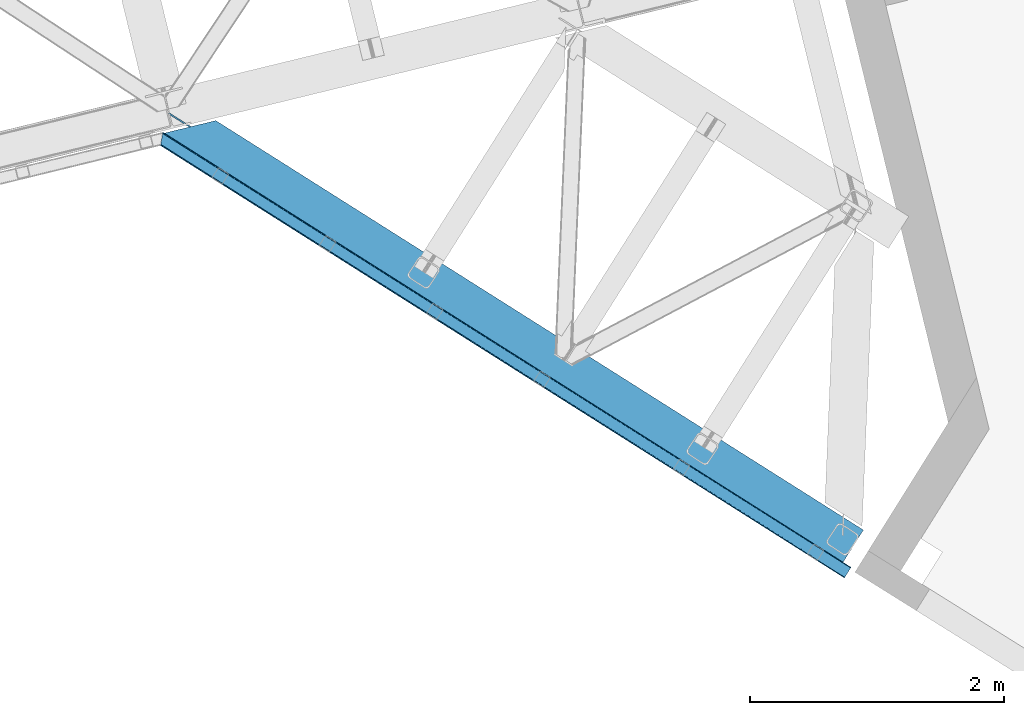
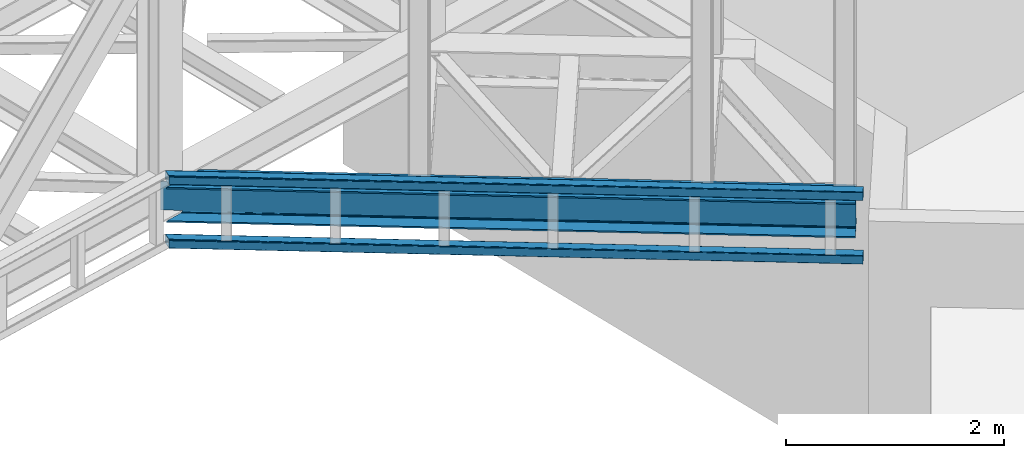
# One storey, part 71 of 93: 3 beams.
"""IFC4 building model written with IfcOpenShell, lengths in millimetres."""

from ifc_helpers import new_model, entity, si_unit, converted_unit, derived_unit, direction, frame, origin, place, context, subcontext, project, spatial, triangles, polygons, material, type_object, element, save


model = new_model("IFC4")

# Units and contexts
model_context = context("Model", 3, precision=0.01, world=origin(), true_north=direction((6.12303176911189e-17, 1.0)))
plan_context = context("Plan", 3, precision=0.01, world=origin(), true_north=direction((6.12303176911189e-17, 1.0)))
body_context = subcontext(model_context, "Body", "Model", "MODEL_VIEW")
ifc_project = project(units=[si_unit("LENGTHUNIT", "METRE", prefix="MILLI"), si_unit("AREAUNIT", "SQUARE_METRE"), si_unit("VOLUMEUNIT", "CUBIC_METRE"), converted_unit("PLANEANGLEUNIT", "DEGREE", entity("IfcRatioMeasure", 0.0174532925199433), si_unit("PLANEANGLEUNIT", "RADIAN"), dimensions=[0, 0, 0, 0, 0, 0, 0]), si_unit("MASSUNIT", "GRAM", prefix="KILO"), derived_unit("MASSDENSITYUNIT", [(si_unit("MASSUNIT", "GRAM", prefix="KILO"), 1), (si_unit("LENGTHUNIT", "METRE"), -3)]), derived_unit("MOMENTOFINERTIAUNIT", [(si_unit("LENGTHUNIT", "METRE"), 4)]), si_unit("TIMEUNIT", "SECOND"), si_unit("FREQUENCYUNIT", "HERTZ"), si_unit("THERMODYNAMICTEMPERATUREUNIT", "DEGREE_CELSIUS"), derived_unit("THERMALTRANSMITTANCEUNIT", [(si_unit("MASSUNIT", "GRAM", prefix="KILO"), 1), (si_unit("THERMODYNAMICTEMPERATUREUNIT", "KELVIN"), -1), (si_unit("TIMEUNIT", "SECOND"), -3)]), derived_unit("VOLUMETRICFLOWRATEUNIT", [(si_unit("LENGTHUNIT", "METRE"), 3), (si_unit("TIMEUNIT", "SECOND"), -1)]), derived_unit("MASSFLOWRATEUNIT", [(si_unit("MASSUNIT", "GRAM", prefix="KILO"), 1), (si_unit("TIMEUNIT", "SECOND"), -1)]), derived_unit("ROTATIONALFREQUENCYUNIT", [(si_unit("TIMEUNIT", "SECOND"), -1)]), si_unit("ELECTRICCURRENTUNIT", "AMPERE"), si_unit("ELECTRICVOLTAGEUNIT", "VOLT"), si_unit("POWERUNIT", "WATT"), si_unit("FORCEUNIT", "NEWTON", prefix="KILO"), si_unit("ILLUMINANCEUNIT", "LUX"), si_unit("LUMINOUSFLUXUNIT", "LUMEN"), si_unit("LUMINOUSINTENSITYUNIT", "CANDELA"), derived_unit("USERDEFINED", [(si_unit("MASSUNIT", "GRAM", prefix="KILO"), -1), (si_unit("LENGTHUNIT", "METRE"), -2), (si_unit("TIMEUNIT", "SECOND"), 3), (si_unit("LUMINOUSFLUXUNIT", "LUMEN"), 1)]), derived_unit("LINEARVELOCITYUNIT", [(si_unit("LENGTHUNIT", "METRE"), 1), (si_unit("TIMEUNIT", "SECOND"), -1)]), si_unit("PRESSUREUNIT", "PASCAL"), derived_unit("USERDEFINED", [(si_unit("LENGTHUNIT", "METRE"), -2), (si_unit("MASSUNIT", "GRAM", prefix="KILO"), 1), (si_unit("TIMEUNIT", "SECOND"), -2)]), derived_unit("LINEARFORCEUNIT", [(si_unit("MASSUNIT", "GRAM", prefix="KILO"), 1), (si_unit("LENGTHUNIT", "METRE"), 1), (si_unit("TIMEUNIT", "SECOND"), -2), (si_unit("LENGTHUNIT", "METRE"), -1)]), derived_unit("PLANARFORCEUNIT", [(si_unit("MASSUNIT", "GRAM", prefix="KILO"), 1), (si_unit("LENGTHUNIT", "METRE"), 1), (si_unit("TIMEUNIT", "SECOND"), -2), (si_unit("LENGTHUNIT", "METRE"), -2)])], contexts=[model_context, plan_context])

# Site, building, storey
site_placement = place(None, origin())
site = spatial("IfcSite", under=ifc_project, at=site_placement, CompositionType="ELEMENT")
building_placement = place(site_placement, origin())
building = spatial("IfcBuilding", under=site, at=building_placement, CompositionType="ELEMENT")
storey_placement = place(building_placement, frame((0.0, 0.0, 15900.0)))
storey = spatial("IfcBuildingStorey", under=building, at=storey_placement, CompositionType="ELEMENT", Elevation=15900.0)

# Beams
ifc_material = material(Name="Metal painted (White)")
beam_type_1 = type_object("IfcBeamType", PredefinedType="BEAM")
beam_1_placement = place(storey_placement, frame((-5441.52292405656, 12718.8983900712, 3293.0)))
element("IfcBeam", 1, at=beam_1_placement, inside=storey, type_object=beam_type_1, material=ifc_material, ObjectType="Steel Beam", PredefinedType="BEAM", context=body_context, shape_type="Tessellation", body=[
    polygons([(5348.49662777212, 2.16573425859679e-12, 376.000000000005), (4.33146851719357e-12, 3381.27208353849, 376.000000000005), (165.112842431303, 3421.52008574059, 376.000000000005), (1093.62086845177, 2834.52555508644, 376.000000000005), (2173.67127244742, 2151.72727848622, 376.000000000005), (3253.72167644305, 1468.92900188599, 376.000000000005), (4333.77208043868, 786.130725285767, 376.000000000005), (5413.82248443432, 103.332448685544, 376.000000000005), (5348.49662777212, 2.16573425859679e-12, 392.000000000006), (4.33146851719357e-12, 3381.27208353849, 392.000000000006), (5508.8054784769, 253.576561191515, 392.000000000006), (405.184889401983, 3480.04018710194, 392.000000000006), (210.481526452577, 3432.57918246201, 356.00000000001), (194.703362949402, 3428.73308817842, 356.00000000001), (192.564591019407, 3428.21173989272, 362.419035512034), (186.123501179538, 3426.64165609887, 369.556349186108), (176.483729007347, 3424.29185964512, 374.325349715257), (405.18488940198, 3480.04018710194, 376.000000000001), (240.072046970671, 3439.79218489983, 376.000000000005), (228.701160394625, 3437.02041099531, 374.325349715252), (219.061388222436, 3434.67061454156, 369.556349186108), (212.620298382568, 3433.1005307477, 362.419035512034), (5348.49662777213, 2.16573425859679e-12, 2.16573425859679e-12), (5508.8054784769, 253.576561191515, 2.16573425859679e-12), (5508.8054784769, 253.576561191517, 16.000000000005), (5443.4796218147, 150.244112505971, 16.000000000005), (5438.98080212478, 143.127878927001, 17.674650284756), (5435.16688695074, 137.095027401615, 22.4436508139004), (5432.61851030462, 133.064004886613, 29.5809644879719), (5431.72363942969, 131.648498018593, 38.0000000000065), (5431.72363942968, 131.648498018593, 354.000000000006), (5432.61851030462, 133.064004886613, 362.419035512034), (5435.16688695074, 137.095027401613, 369.556349186108), (5438.98080212478, 143.127878927001, 374.325349715248), (5443.4796218147, 150.244112505971, 376.000000000005), (5508.8054784769, 253.576561191517, 376.000000000001), (5418.32130412425, 110.448682264514, 374.325349715252), (5422.13521929827, 116.481533789893, 369.556349186108), (5424.6835959444, 120.512556304902, 362.419035512034), (5425.57846681934, 121.928063172921, 354.000000000006), (5425.57846681934, 121.928063172921, 38.0000000000065), (5424.6835959444, 120.512556304902, 29.5809644879719), (5422.13521929827, 116.481533789891, 22.4436508138982), (5418.32130412425, 110.448682264514, 17.6746502847538), (5413.82248443432, 103.332448685544, 16.000000000005), (5348.49662777213, 2.16573425859679e-12, 16.000000000005), (4539.61123918262, 721.661679363439, 376.000000000005), (3635.74285655055, 1293.0792462209, 376.000000000005), (2731.87447391849, 1864.49681307837, 376.000000000005), (1828.00609128642, 2435.91437993584, 376.000000000005), (924.137708654353, 3007.3319467933, 376.000000000005), (4344.63319194877, 803.310832905123, 362.419035512034), (4345.5280628237, 804.726339773147, 354.000000000006), (3264.58278795313, 1486.10910950535, 362.419035512034), (3265.47765882807, 1487.52461637337, 354.000000000006), (2184.5323839575, 2168.90738610558, 362.419035512034), (2185.42725483244, 2170.3228929736, 354.000000000006), (1104.48197996186, 2851.7056627058, 362.419035512034), (1105.3768508368, 2853.12116957382, 354.000000000006), (4342.08481530264, 799.279810390127, 369.556349186108), (3262.034411307, 1482.07808699035, 369.556349186108), (2181.98400731137, 2164.87636359058, 369.556349186108), (1101.93360331573, 2847.6746401908, 369.556349186108), (4338.27090012861, 793.246958864737, 374.325349715252), (3258.22049613296, 1476.04523546496, 374.325349715252), (2178.17009213734, 2158.84351206519, 374.325349715252), (1098.1196881417, 2841.64178866541, 374.325349715257), (25.277767615974, 3535.84244536922, 356.000000000006), (25.3283289836519, 3535.91175797538, 353.999999604171), (4535.11241949271, 714.545445784473, 374.325349715252), (3631.24403686065, 1285.96301264194, 374.325349715252), (2727.37565422857, 1857.3805794994, 374.325349715252), (1823.5072715965, 2428.79814635686, 374.325349715252), (919.638888964427, 3000.21571321434, 374.325349715252), (4531.29850431868, 708.512594259083, 369.556349186108), (3627.43012168661, 1279.93016111655, 369.556349186108), (2723.56173905454, 1851.34772797402, 369.556349186108), (1819.69335642247, 2422.76529483148, 369.556349186108), (915.824973790396, 2994.18286168895, 369.556349186108), (4528.75012767254, 704.481571744081, 362.419035512034), (3624.88174504048, 1275.89913860154, 362.419035512034), (2721.01336240841, 1847.31670545901, 362.419035512034), (1817.14497977633, 2418.73427231648, 362.419035512034), (913.276597144271, 2990.15183917395, 362.419035512034), (4527.85525679761, 703.066064876057, 354.000000000006), (3623.98687416554, 1274.48363173353, 354.000000000006), (2720.11849153348, 1845.90119859099, 354.000000000006), (1816.2501089014, 2417.31876544846, 354.000000000006), (912.381726269338, 2988.73633230592, 354.000000000006), (40.8590053356167, 3539.70363258882, 353.999999900937), (40.9815723062875, 3539.73554863413, 356.000000000006), (25.3276901044207, 3535.9143676771, 35.9999997385335), (25.3273911802177, 3535.91558872633, 37.9999998013979), (40.8572852816821, 3539.71065868616, 38.0000002626798), (40.9802875962089, 3539.74079643359, 36.0000002701953), (1105.37685083679, 2853.12116957382, 38.0000000000044), (2185.42725483242, 2170.3228929736, 38.0000000000022), (3265.47765882807, 1487.52461637337, 38.0000000000065), (4345.5280628237, 804.726339773145, 38.0000000000065), (4527.85525679762, 703.066064876057, 38.0000000000065), (3623.98687416554, 1274.48363173353, 38.0000000000065), (2720.11849153347, 1845.90119859099, 38.0000000000065), (1816.2501089014, 2417.31876544846, 38.0000000000065), (912.381726269339, 2988.73633230592, 38.0000000000044), (4338.27090012861, 793.246958864737, 17.6746502847538), (4333.77208043868, 786.130725285771, 16.0000000000072), (3258.22049613296, 1476.04523546496, 17.6746502847538), (3253.72167644305, 1468.92900188599, 16.000000000005), (2178.17009213734, 2158.84351206518, 17.6746502847538), (2173.67127244742, 2151.72727848622, 16.000000000005), (1098.1196881417, 2841.64178866541, 17.674650284756), (1093.62086845177, 2834.52555508644, 16.000000000005), (4342.08481530264, 799.279810390123, 22.4436508139004), (3262.034411307, 1482.07808699035, 22.4436508138982), (2181.98400731137, 2164.87636359057, 22.4436508138982), (1101.93360331573, 2847.67464019079, 22.443650813896), (4344.63319194876, 803.310832905125, 29.5809644879698), (3264.58278795312, 1486.10910950534, 29.5809644879762), (2184.5323839575, 2168.90738610557, 29.5809644879741), (1104.48197996185, 2851.70566270579, 29.5809644879741), (192.564591019411, 3428.21173989272, 29.5809644879719), (186.123501179543, 3426.64165609887, 22.4436508139004), (176.483729007351, 3424.29185964512, 17.6746502847517), (165.112842431302, 3421.52008574059, 16.000000000005), (194.703362949402, 3428.73308817842, 36.0000000000026), (4.33146851719357e-12, 3381.27208353849, 16.000000000005), (3.24860138789518e-12, 3381.27208353849, 2.16573425859679e-12), (240.072046970672, 3439.79218489983, 16.000000000005), (405.18488940198, 3480.04018710194, 16.000000000005), (405.184889401981, 3480.04018710194, 2.16573425859679e-12), (210.481526452582, 3432.57918246201, 36.0000000000048), (212.620298382577, 3433.10053074771, 29.5809644879719), (219.061388222445, 3434.67061454156, 22.4436508139004), (228.701160394625, 3437.02041099531, 17.6746502847538), (924.137708654352, 3007.3319467933, 16.0000000000029), (1828.00609128641, 2435.91437993584, 16.0000000000029), (2731.87447391849, 1864.49681307837, 16.0000000000029), (3635.74285655055, 1293.0792462209, 16.000000000005), (4539.61123918262, 721.661679363439, 16.000000000005), (4528.75012767254, 704.481571744079, 29.5809644879719), (3624.88174504048, 1275.89913860154, 29.5809644879698), (2721.01336240841, 1847.31670545902, 29.5809644879719), (1817.14497977633, 2418.73427231648, 29.5809644879719), (913.276597144274, 2990.15183917395, 29.5809644879719), (4531.29850431868, 708.512594259083, 22.4436508138982), (3627.43012168661, 1279.93016111655, 22.4436508139025), (2723.56173905453, 1851.34772797401, 22.4436508139025), (1819.69335642247, 2422.76529483147, 22.4436508138982), (915.824973790396, 2994.18286168895, 22.4436508139004), (4535.11241949271, 714.545445784471, 17.674650284756), (3631.24403686065, 1285.96301264194, 17.6746502847517), (2727.37565422857, 1857.3805794994, 17.6746502847538), (1823.5072715965, 2428.79814635687, 17.674650284756), (919.638888964427, 3000.21571321434, 17.6746502847538)], [[[1, 2, 3, 4, 5, 6, 7, 8]], [[9, 10, 2, 1]], [[11, 12, 10, 9]], [[13, 14, 15, 16, 17, 3, 2, 10, 12, 18, 19, 20, 21, 22]], [[23, 24, 25, 26, 27, 28, 29, 30, 31, 32, 33, 34, 35, 36, 11, 9, 1, 8, 37, 38, 39, 40, 41, 42, 43, 44, 45, 46]], [[36, 18, 12, 11]], [[35, 47, 48, 49, 50, 51, 19, 18, 36]], [[52, 53, 40, 39]], [[54, 55, 53, 52]], [[56, 57, 55, 54]], [[58, 59, 57, 56]], [[60, 52, 39, 38]], [[61, 54, 52, 60]], [[62, 56, 54, 61]], [[63, 58, 56, 62]], [[64, 60, 38, 37]], [[65, 61, 60, 64]], [[66, 62, 61, 65]], [[67, 63, 62, 66]], [[7, 64, 37, 8]], [[6, 65, 64, 7]], [[5, 66, 65, 6]], [[4, 67, 66, 5]], [[3, 17, 67, 4]], [[17, 16, 63, 67]], [[16, 15, 58, 63]], [[59, 14, 68, 69]], [[58, 14, 59]], [[14, 58, 15]], [[70, 47, 35, 34]], [[71, 48, 47, 70]], [[72, 49, 48, 71]], [[73, 50, 49, 72]], [[74, 51, 50, 73]], [[75, 70, 34, 33]], [[76, 71, 70, 75]], [[77, 72, 71, 76]], [[78, 73, 72, 77]], [[79, 74, 73, 78]], [[80, 75, 33, 32]], [[81, 76, 75, 80]], [[82, 77, 76, 81]], [[83, 78, 77, 82]], [[84, 79, 78, 83]], [[85, 80, 32, 31]], [[86, 81, 80, 85]], [[87, 82, 81, 86]], [[88, 83, 82, 87]], [[89, 84, 83, 88]], [[22, 21, 79, 84]], [[21, 20, 74, 79]], [[20, 19, 51, 74]], [[13, 90, 91]], [[84, 13, 22]], [[89, 13, 84]], [[13, 89, 90]], [[91, 68, 14, 13]], [[92, 93, 69, 68, 91, 90, 94, 95]], [[69, 93, 96, 97, 98, 99, 41, 40, 53, 55, 57, 59]], [[30, 100, 101, 102, 103, 104, 94, 90, 89, 88, 87, 86, 85, 31]], [[105, 106, 45, 44]], [[107, 108, 106, 105]], [[109, 110, 108, 107]], [[111, 112, 110, 109]], [[113, 105, 44, 43]], [[114, 107, 105, 113]], [[115, 109, 107, 114]], [[116, 111, 109, 115]], [[117, 113, 43, 42]], [[118, 114, 113, 117]], [[119, 115, 114, 118]], [[120, 116, 115, 119]], [[99, 117, 42, 41]], [[98, 118, 117, 99]], [[97, 119, 118, 98]], [[96, 120, 119, 97]], [[121, 122, 116, 120]], [[122, 123, 111, 116]], [[123, 124, 112, 111]], [[125, 93, 92]], [[120, 125, 121]], [[96, 125, 120]], [[125, 96, 93]], [[46, 126, 127, 23]], [[45, 106, 108, 110, 112, 124, 126, 46]], [[128, 129, 130, 127, 126, 124, 123, 122, 121, 125, 131, 132, 133, 134]], [[23, 127, 130, 24]], [[24, 130, 129, 25]], [[25, 129, 128, 135, 136, 137, 138, 139, 26]], [[140, 100, 30, 29]], [[141, 101, 100, 140]], [[142, 102, 101, 141]], [[143, 103, 102, 142]], [[144, 104, 103, 143]], [[145, 140, 29, 28]], [[146, 141, 140, 145]], [[147, 142, 141, 146]], [[148, 143, 142, 147]], [[149, 144, 143, 148]], [[150, 145, 28, 27]], [[151, 146, 145, 150]], [[152, 147, 146, 151]], [[153, 148, 147, 152]], [[154, 149, 148, 153]], [[139, 150, 27, 26]], [[138, 151, 150, 139]], [[137, 152, 151, 138]], [[136, 153, 152, 137]], [[135, 154, 153, 136]], [[128, 134, 154, 135]], [[134, 133, 149, 154]], [[133, 132, 144, 149]], [[104, 131, 95, 94]], [[104, 132, 131]], [[132, 104, 144]], [[131, 125, 92, 95]]], closed=True),
])
beam_type_2 = type_object("IfcBeamType", PredefinedType="BEAM")
beam_2_placement = place(storey_placement, frame((-5471.53637237549, 12594.3091644287, 3780.00573120117)))
element("IfcBeam", 2, at=beam_2_placement, inside=storey, type_object=beam_type_2, ObjectType="Steel Beam", PredefinedType="BEAM", context=body_context, shape_type="Tessellation", body=[
    triangles([(15.8013610839844, 3503.0245513916, 99.9985473632805), (1.75745086669849, 3417.25885620117, 99.9985473632805), (5436.55335826278, 76.0732635498061, 99.9985473632805), (5393.80616054535, 8.45297241210938, 99.9985473632805), (1.13539581298755, 3413.46722717285, 98.5335205078118), (5391.76071853638, 5.21828613281286, 99.2381286621094), (0.517410278320313, 3409.67792358399, 97.070819091794), (5390.02611329555, 2.47543029785265, 97.070819091794), (0.258705139160156, 3408.1070892334, 93.533825683593), (5388.86898915768, 0.644146728516716, 93.8268310546846), (0.0, 3406.53741760254, 89.999157714843), (5388.46101987362, 0.0, 89.999157714843), (5388.46101987362, 0.0, 9.9993896484375), (0.0, 3406.53741760254, 9.9993896484375), (5388.86898915768, 0.644146728516716, 6.17171630859229), (5390.02611329555, 2.47543029785265, 2.92772827148292), (0.258705139160156, 3408.1070892334, 6.46239624023292), (5391.76071853638, 5.21828613281286, 0.760418701171147), (0.517410278320313, 3409.67792358399, 2.92772827148292), (5393.80616054535, 8.45297241210938, 0.0), (1.13539581298755, 3413.46722717285, 1.46270141601417), (1.75745086669849, 3417.25769348145, 0.0), (15.8013610839844, 3503.0245513916, 0.0), (5436.55335826278, 76.0732635498061, 0.0), (5438.59880481362, 79.3079498291027, 0.760418701171147), (5440.33340778351, 82.0508056640629, 2.92772827148292), (16.4234161376953, 3506.8150177002, 1.46270141601417), (5441.49046606421, 83.8820892333988, 6.17171630859229), (17.046052551269, 3510.60548400879, 2.92772827148292), (5441.89843534827, 84.5262359619155, 9.9993896484375), (17.3001068115227, 3512.17515563965, 6.46239624023292), (17.5588119506829, 3513.74482727051, 9.9993896484375), (5441.89843534827, 84.5262359619155, 89.999157714843), (17.5588119506829, 3513.74482727051, 89.999157714843), (17.3001068115227, 3512.17515563965, 93.533825683593), (5441.49046606421, 83.8820892333988, 93.8268310546846), (17.0454711914063, 3510.60548400879, 97.070819091794), (5440.33340778351, 82.0508056640629, 97.070819091794), (16.4234161376953, 3506.8150177002, 98.5335205078118), (5438.59880481362, 79.3079498291027, 99.2381286621094), (5437.66312882304, 77.8243194580082, 92.0687988281243), (5438.82018710375, 79.6567657470714, 88.8248107910149), (5439.22815638781, 80.2997497558608, 84.9994628906243), (5433.88307930231, 71.8467773437515, 94.9988525390618), (5435.92852585316, 75.081463623048, 94.2384338378906), (5437.66312882304, 77.8243194580082, 7.92742309570167), (5439.22815638781, 80.2997497558608, 14.9990844726563), (5438.82018710375, 79.6567657470714, 11.171411132811), (5433.88307930231, 71.8467773437515, 4.99969482421875), (5435.92852585316, 75.081463623048, 5.7601135253899), (5392.69638998508, 6.70191650390734, 92.0687988281243), (5396.47644177675, 12.6794586181641, 94.9988525390618), (5394.43099522591, 9.44477233886755, 94.2384338378906), (5391.13129656315, 4.22648620605469, 84.9994628906243), (5391.53926584721, 4.86947021484411, 88.8248107910149), (5392.69638998508, 6.70191650390734, 7.92742309570167), (5396.47644177675, 12.6794586181641, 4.99969482421875), (5394.43099522591, 9.44477233886755, 5.7601135253899), (5391.13129656315, 4.22648620605469, 14.9990844726563), (5391.53926584721, 4.86947021484411, 11.171411132811), (16.4234161376953, 3506.8150177002, 11.4644165039063), (16.6821212768555, 3508.38468933106, 14.9990844726563), (16.1647109985352, 3505.24418334961, 7.92742309570167), (16.6821212768555, 3508.38468933106, 84.9994628906243), (14.9252517700188, 3497.66441345215, 4.99969482421875), (2.63356018066406, 3422.6178314209, 4.99969482421875), (15.5473068237297, 3501.45487976074, 6.46239624023292), (16.1647109985352, 3505.24418334961, 92.0687988281243), (16.4234161376953, 3506.8150177002, 88.5341308593743), (14.9252517700188, 3497.66441345215, 94.9988525390618), (15.5473068237297, 3501.45487976074, 93.533825683593), (1.39410095214771, 3415.03806152344, 7.92742309570167), (2.01615600585865, 3418.82852783203, 6.46239624023292), (0.880760192871094, 3411.89871826172, 14.9990844726563), (1.13539581298755, 3413.46722717285, 11.4644165039063), (2.01615600585865, 3418.82852783203, 93.533825683593), (1.39410095214771, 3415.03806152344, 92.0687988281243), (1.13539581298755, 3413.46722717285, 88.5341308593743), (2.63356018066406, 3422.6178314209, 94.9988525390618), (0.880760192871094, 3411.89871826172, 84.9994628906243)], [[1, 2, 3], [4, 3, 2], [4, 2, 5], [6, 5, 7], [8, 7, 9], [10, 9, 11], [11, 12, 10], [9, 10, 8], [7, 8, 6], [5, 6, 4], [13, 12, 14], [11, 14, 12], [15, 13, 14], [16, 15, 17], [18, 16, 19], [20, 18, 21], [21, 22, 20], [19, 21, 18], [17, 19, 16], [14, 17, 15], [22, 23, 24], [24, 20, 22], [25, 24, 23], [26, 25, 27], [28, 26, 29], [30, 28, 31], [31, 32, 30], [29, 31, 28], [27, 29, 26], [23, 27, 25], [33, 30, 32], [32, 34, 33], [33, 34, 35], [36, 35, 37], [38, 37, 39], [40, 39, 1], [1, 3, 40], [39, 40, 38], [37, 38, 36], [35, 36, 33], [36, 41, 42], [43, 30, 33], [36, 42, 33], [36, 38, 41], [42, 43, 33], [41, 38, 40], [44, 3, 4], [3, 45, 40], [45, 3, 44], [45, 41, 40], [28, 46, 26], [47, 30, 43], [30, 48, 28], [48, 30, 47], [28, 48, 46], [24, 49, 20], [25, 26, 46], [46, 50, 25], [50, 49, 24], [24, 25, 50], [51, 6, 8], [4, 52, 44], [4, 53, 52], [53, 4, 6], [51, 53, 6], [54, 12, 13], [10, 55, 51], [8, 10, 51], [55, 10, 12], [54, 55, 12], [18, 56, 16], [20, 49, 57], [57, 58, 20], [58, 56, 18], [18, 20, 58], [15, 16, 56], [13, 59, 54], [60, 13, 15], [13, 60, 59], [60, 15, 56], [61, 62, 32], [63, 31, 29], [63, 29, 27], [32, 62, 64], [32, 31, 61], [63, 61, 31], [65, 23, 66], [27, 23, 67], [65, 67, 23], [27, 67, 63], [35, 68, 37], [64, 34, 32], [34, 69, 35], [69, 34, 64], [35, 69, 68], [1, 70, 2], [39, 37, 68], [71, 39, 68], [1, 71, 70], [1, 39, 71], [72, 21, 19], [22, 66, 23], [22, 73, 66], [73, 22, 21], [72, 73, 21], [74, 14, 11], [17, 75, 72], [72, 19, 17], [17, 14, 75], [74, 75, 14], [5, 2, 76], [77, 5, 76], [78, 9, 77], [79, 2, 70], [2, 79, 76], [77, 7, 5], [11, 80, 74], [9, 78, 11], [80, 11, 78], [9, 7, 77], [79, 70, 44], [44, 52, 79], [55, 54, 80], [51, 55, 78], [53, 51, 77], [52, 53, 76], [76, 79, 52], [77, 76, 53], [78, 77, 51], [80, 78, 55], [54, 59, 74], [74, 80, 54], [57, 66, 73], [58, 73, 72], [56, 72, 75], [60, 75, 74], [74, 59, 60], [75, 60, 56], [72, 56, 58], [73, 58, 57], [65, 66, 49], [57, 49, 66], [47, 62, 61], [48, 61, 63], [46, 63, 67], [50, 67, 65], [65, 49, 50], [67, 50, 46], [63, 46, 48], [61, 48, 47], [47, 43, 62], [64, 62, 43], [45, 44, 70], [41, 45, 71], [42, 41, 68], [43, 42, 69], [69, 64, 43], [68, 69, 42], [71, 68, 41], [70, 71, 45]]),
])
beam_type_3 = type_object("IfcBeamType", PredefinedType="BEAM")
beam_3_placement = place(storey_placement, frame((-5471.53637237549, 12594.3091644287, 3068.00500488281)))
element("IfcBeam", 3, at=beam_3_placement, inside=storey, type_object=beam_type_3, ObjectType="Steel Beam", PredefinedType="BEAM", context=body_context, shape_type="Tessellation", body=[
    triangles([(5441.89843534827, 84.5262359619155, 89.999157714843), (17.5588119506829, 3513.74482727051, 49.9934600830093), (17.5588119506829, 3513.74482727051, 89.999157714843), (5441.89843534827, 84.5262359619155, 9.9993896484375), (17.5588119506829, 3513.74482727051, 37.9174530029304), (17.5588119506829, 3513.74482727051, 9.952880859375), (5438.56435924172, 79.2521392822273, 0.733676147461665), (5436.55335826278, 76.0732635498061, 0.0), (15.8013610839844, 3503.0245513916, 0.0), (5440.31632125378, 82.0217376708988, 2.89517211914063), (16.4106262207024, 3506.74990539551, 1.42898254394458), (5441.48746161461, 83.8751129150405, 6.15078735351563), (17.0402389526362, 3510.56943969727, 2.89517211914063), (17.3018508911127, 3512.16701660156, 6.44611816406177), (1.75745086669849, 3417.25769348145, 0.0), (5393.80616054535, 8.45297241210938, 0.0), (5389.43155474663, 1.53711547851708, 4.24974060058594), (5388.65123355389, 0.299981689453489, 7.36117858886792), (0.0895294189449487, 3407.09203491211, 7.39373474121021), (0.136038208007449, 3407.35364685059, 6.17287902831958), (5390.73057610989, 3.59164123535265, 1.81849365234302), (0.349978637695131, 3408.65589294434, 4.35438537597656), (0.517410278320313, 3409.67792358399, 2.92889099121021), (5392.39668989182, 6.22287597656396, 0.353466796874272), (0.761000061034792, 3411.19178466797, 1.95104370117406), (1.03133239746057, 3412.83354492188, 0.890643310547603), (1.30050201415997, 3414.47763061524, 0.55926818847729), (5388.46101987362, 0.0, 9.9993896484375), (0.0, 3406.53741760254, 9.9993896484375), (5388.46101987362, 0.0, 89.999157714843), (0.0, 3406.53741760254, 49.9934600830093), (0.0, 3406.53741760254, 89.999157714843), (5393.80616054535, 8.45297241210938, 99.9997100830078), (1.75745086669849, 3417.25769348145, 99.9997100830078), (1.13539581298755, 3413.46722717285, 98.5346832275391), (5391.76071853638, 5.21828613281286, 99.2381286621094), (0.517410278320313, 3409.67792358399, 97.0708190917976), (5390.02611329555, 2.47543029785265, 97.0708190917976), (0.258705139160156, 3408.1070892334, 93.5349884033203), (5388.86898915768, 0.644146728516716, 93.8268310546882), (15.8013610839844, 3503.0245513916, 99.9997100830078), (5436.55335826278, 76.0732635498061, 99.9997100830078), (17.3001068115227, 3512.17515563965, 93.5349884033203), (5441.49046606421, 83.8820892333988, 93.8268310546882), (17.046052551269, 3510.60548400879, 97.0708190917976), (5440.33340778351, 82.0508056640629, 97.0708190917976), (16.4234161376953, 3506.8150177002, 98.5346832275391), (5438.59880481362, 79.3079498291027, 99.2381286621094), (16.6821212768555, 3508.38468933106, 14.9990844726563), (16.5879409790032, 3507.82890930176, 12.393429565429), (16.5460830688471, 3507.56846008301, 11.1725738525383), (14.9252517700188, 3497.66441345215, 4.99969482421875), (2.63356018066406, 3422.6178314209, 4.99969482421875), (2.01615600585865, 3418.82852783203, 6.46355895996021), (1.39410095214771, 3415.03806152344, 7.92858581542896), (15.5955596923823, 3501.76648864746, 5.76127624511719), (15.3833633422846, 3500.45726623535, 5.51826782226635), (16.1647109985352, 3505.24418334961, 7.92858581542896), (15.915307617187, 3503.71520690918, 6.97515563964771), (16.3321426391594, 3506.26621398926, 9.3552429199226), (16.6821212768555, 3508.38468933106, 84.9994628906243), (16.6821212768555, 3508.38468933106, 49.9934600830093), (1.39410095214771, 3415.03806152344, 92.0711242675789), (0.880760192871094, 3411.89871826172, 14.9990844726563), (1.13539581298755, 3413.46722717285, 11.4644165039063), (0.880760192871094, 3411.89871826172, 49.9934600830093), (1.13539581298755, 3413.46722717285, 88.5352935791016), (0.880760192871094, 3411.89871826172, 84.9994628906243), (16.1647109985352, 3505.24418334961, 92.0711242675789), (16.4234161376953, 3506.8150177002, 88.5352935791016), (14.9252517700188, 3497.66441345215, 95.0000152587891), (2.63356018066406, 3422.6178314209, 95.0000152587891), (15.5473068237297, 3501.45487976074, 93.5349884033203), (2.01615600585865, 3418.82852783203, 93.5349884033203), (5437.66312882304, 77.8243194580082, 92.0711242675789), (5438.82018710375, 79.6567657470714, 88.8259735107422), (5439.22815638781, 80.2997497558608, 84.9994628906243), (5439.22815638781, 80.2997497558608, 14.9990844726563), (5433.88307930231, 71.8467773437515, 95.0000152587891), (5435.92852585316, 75.081463623048, 94.2384338378906), (5436.95408098698, 76.7069458007827, 6.81818847656177), (5439.03794270754, 79.9997680664073, 12.3608734130867), (5438.2531000793, 78.7626342773438, 9.24943542480469), (5435.29254768491, 74.0768737792969, 5.35432434082031), (5433.88307930231, 71.8467773437515, 4.99969482421875), (5392.69638998508, 6.70191650390734, 92.0711242675789), (5391.53926584721, 4.86947021484411, 88.8259735107422), (5396.47644177675, 12.6794586181641, 95.0000152587891), (5394.43099522591, 9.44477233886755, 94.2384338378906), (5391.13129656315, 4.22648620605469, 84.9994628906243), (5391.13129656315, 4.22648620605469, 14.9990844726563), (5392.69638998508, 6.70191650390734, 7.92858581542896), (5396.47644177675, 12.6794586181641, 4.99969482421875), (5394.43099522591, 9.44477233886755, 5.76127624511719), (5391.53926584721, 4.86947021484411, 11.1725738525383)], [[1, 2, 3], [1, 4, 2], [4, 5, 2], [4, 6, 5], [7, 8, 9], [10, 7, 11], [12, 10, 13], [4, 12, 14], [14, 6, 4], [13, 14, 12], [11, 13, 10], [9, 11, 7], [15, 9, 8], [8, 16, 15], [17, 18, 19], [19, 20, 17], [21, 17, 22], [22, 23, 21], [24, 21, 25], [25, 26, 24], [16, 24, 27], [18, 28, 29], [29, 19, 18], [27, 15, 16], [26, 27, 24], [23, 25, 21], [20, 22, 17], [30, 31, 28], [31, 30, 32], [31, 29, 28], [33, 34, 35], [36, 35, 37], [38, 37, 39], [40, 39, 32], [32, 30, 40], [39, 40, 38], [37, 38, 36], [35, 36, 33], [41, 34, 42], [33, 42, 34], [1, 3, 43], [44, 43, 45], [46, 45, 47], [48, 47, 41], [41, 42, 48], [47, 48, 46], [45, 46, 44], [43, 44, 1], [49, 6, 50], [51, 50, 6], [52, 9, 53], [15, 53, 9], [54, 27, 55], [53, 15, 54], [54, 15, 27], [25, 23, 55], [55, 27, 26], [55, 26, 25], [56, 9, 57], [52, 57, 9], [58, 11, 59], [58, 13, 11], [11, 56, 59], [9, 56, 11], [6, 14, 51], [14, 13, 58], [58, 60, 14], [60, 51, 14], [2, 61, 3], [6, 49, 5], [5, 62, 2], [49, 62, 5], [62, 61, 2], [63, 39, 37], [64, 65, 29], [65, 55, 19], [64, 31, 66], [67, 39, 63], [32, 67, 68], [68, 66, 31], [67, 32, 39], [22, 55, 23], [19, 55, 20], [22, 20, 55], [31, 64, 29], [31, 32, 68], [19, 29, 65], [45, 43, 69], [43, 3, 70], [61, 70, 3], [70, 69, 43], [41, 71, 72], [69, 73, 47], [73, 71, 41], [69, 47, 45], [73, 41, 47], [34, 41, 72], [72, 74, 34], [74, 63, 35], [35, 34, 74], [63, 37, 35], [44, 75, 76], [4, 1, 77], [44, 76, 1], [44, 46, 75], [76, 77, 1], [78, 4, 77], [75, 46, 48], [79, 42, 33], [42, 80, 48], [80, 42, 79], [80, 75, 48], [10, 81, 7], [82, 4, 78], [83, 12, 4], [83, 4, 82], [12, 83, 10], [81, 8, 7], [10, 83, 81], [81, 84, 8], [8, 85, 16], [85, 8, 84], [86, 40, 87], [33, 88, 79], [33, 89, 88], [89, 33, 36], [86, 36, 38], [86, 89, 36], [90, 28, 91], [87, 30, 90], [38, 40, 86], [30, 87, 40], [90, 30, 28], [24, 92, 21], [16, 85, 93], [93, 94, 16], [94, 92, 24], [24, 16, 94], [17, 21, 92], [28, 95, 91], [92, 95, 18], [28, 18, 95], [92, 18, 17], [52, 53, 85], [93, 85, 53], [93, 53, 54], [94, 54, 55], [92, 55, 65], [95, 65, 64], [64, 91, 95], [65, 95, 92], [55, 92, 94], [54, 94, 93], [90, 66, 68], [90, 91, 66], [64, 66, 91], [87, 90, 68], [86, 87, 67], [89, 86, 63], [88, 89, 74], [74, 72, 88], [63, 74, 89], [67, 63, 86], [68, 67, 87], [72, 71, 79], [79, 88, 72], [80, 79, 71], [75, 80, 73], [76, 75, 69], [77, 76, 70], [70, 61, 77], [69, 70, 76], [73, 69, 75], [71, 73, 80], [77, 62, 78], [62, 77, 61], [62, 49, 78], [78, 49, 50], [82, 51, 60], [82, 50, 51], [83, 58, 59], [83, 60, 58], [81, 56, 57], [81, 59, 56], [84, 57, 52], [52, 85, 84], [57, 84, 81], [59, 81, 83], [60, 83, 82], [50, 82, 78]]),
])

save(model, "model.ifc")
